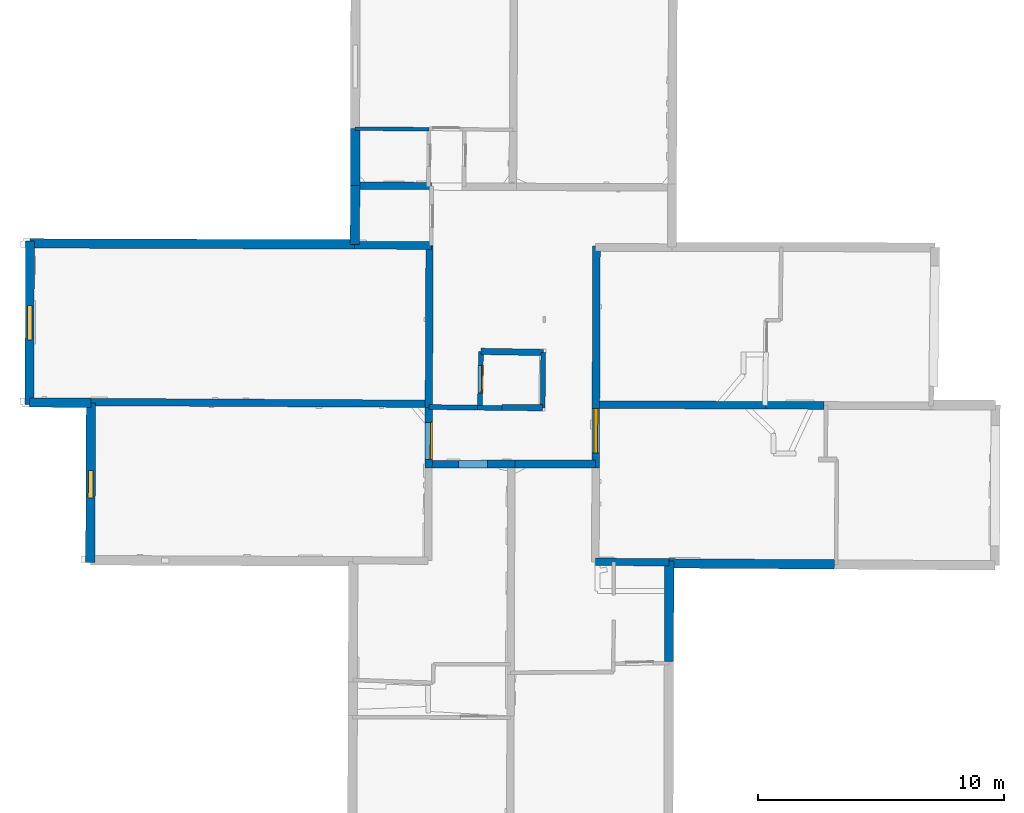
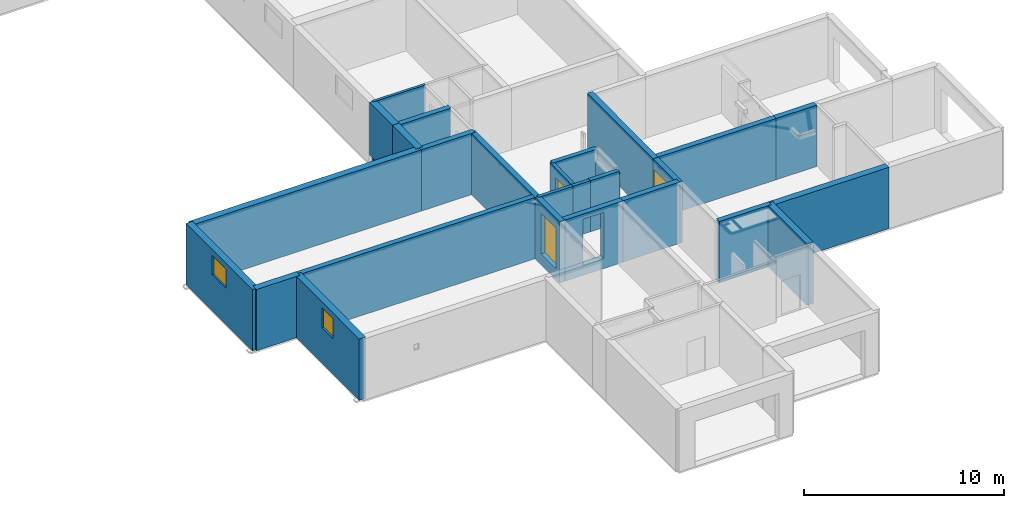
# One storey, part 3 of 12: 27 walls, 3 windows, 2 doors, 6 openings.
"""IFC2X3 building model written with IfcOpenShell, lengths in metres."""

from ifc_helpers import new_model, entity, si_unit, converted_unit, derived_unit, direction, frame, frame_2d, origin, origin_2d_with_axis, place, context, subcontext, project, spatial, polyline, rectangle, outline, extrude, source, transform, mapped, material, layer, layer_set, layer_usage, type_object, type_shapes, element, fill, save


model = new_model("IFC2X3")

# Units and contexts
model_context = context("Model", 3, precision=1e-05, world=origin(), true_north=direction((0.0, 1.0)))
body_context = subcontext(model_context, "Body", "Model", "MODEL_VIEW")
ifc_project = project(units=[si_unit("LENGTHUNIT", "METRE"), si_unit("AREAUNIT", "SQUARE_METRE"), si_unit("VOLUMEUNIT", "CUBIC_METRE"), converted_unit("PLANEANGLEUNIT", "DEGREE", entity("IfcRatioMeasure", 0.0174532925199433), si_unit("PLANEANGLEUNIT", "RADIAN"), dimensions=[0, 0, 0, 0, 0, 0, 0]), si_unit("MASSUNIT", "GRAM", prefix="KILO"), derived_unit("MASSDENSITYUNIT", [(si_unit("MASSUNIT", "GRAM", prefix="KILO"), 1), (si_unit("LENGTHUNIT", "METRE"), -3)]), derived_unit("MOMENTOFINERTIAUNIT", [(si_unit("LENGTHUNIT", "METRE"), 4)]), si_unit("TIMEUNIT", "SECOND"), si_unit("FREQUENCYUNIT", "HERTZ"), si_unit("THERMODYNAMICTEMPERATUREUNIT", "DEGREE_CELSIUS"), derived_unit("THERMALTRANSMITTANCEUNIT", [(si_unit("MASSUNIT", "GRAM", prefix="KILO"), 1), (si_unit("THERMODYNAMICTEMPERATUREUNIT", "KELVIN"), -1), (si_unit("TIMEUNIT", "SECOND"), -3)]), derived_unit("VOLUMETRICFLOWRATEUNIT", [(si_unit("LENGTHUNIT", "METRE"), 3), (si_unit("TIMEUNIT", "SECOND"), -1)]), si_unit("ELECTRICCURRENTUNIT", "AMPERE"), si_unit("ELECTRICVOLTAGEUNIT", "VOLT"), si_unit("POWERUNIT", "WATT"), si_unit("FORCEUNIT", "NEWTON", prefix="KILO"), si_unit("ILLUMINANCEUNIT", "LUX"), si_unit("LUMINOUSFLUXUNIT", "LUMEN"), si_unit("LUMINOUSINTENSITYUNIT", "CANDELA"), derived_unit("USERDEFINED", [(si_unit("MASSUNIT", "GRAM", prefix="KILO"), -1), (si_unit("LENGTHUNIT", "METRE"), -2), (si_unit("TIMEUNIT", "SECOND"), 3), (si_unit("LUMINOUSFLUXUNIT", "LUMEN"), 1)]), derived_unit("LINEARVELOCITYUNIT", [(si_unit("LENGTHUNIT", "METRE"), 1), (si_unit("TIMEUNIT", "SECOND"), -1)]), si_unit("PRESSUREUNIT", "PASCAL"), derived_unit("USERDEFINED", [(si_unit("LENGTHUNIT", "METRE"), -2), (si_unit("MASSUNIT", "GRAM", prefix="KILO"), 1), (si_unit("TIMEUNIT", "SECOND"), -2)]), derived_unit("LINEARFORCEUNIT", [(si_unit("MASSUNIT", "GRAM", prefix="KILO"), 1), (si_unit("LENGTHUNIT", "METRE"), 1), (si_unit("TIMEUNIT", "SECOND"), -2), (si_unit("LENGTHUNIT", "METRE"), -1)]), derived_unit("PLANARFORCEUNIT", [(si_unit("MASSUNIT", "GRAM", prefix="KILO"), 1), (si_unit("LENGTHUNIT", "METRE"), 1), (si_unit("TIMEUNIT", "SECOND"), -2), (si_unit("LENGTHUNIT", "METRE"), -2)])], contexts=[model_context])

# Site, building, storey
placement_1 = place(None, origin())
site = spatial("IfcSite", under=ifc_project, at=placement_1, CompositionType="ELEMENT")
building = spatial("IfcBuilding", under=site, at=placement_1, CompositionType="ELEMENT")
storey_placement = place(placement_1, frame((0.0, 0.0, -1.46125340461731)))
storey = spatial("IfcBuildingStorey", under=building, at=storey_placement, Name="Level 1", CompositionType="ELEMENT", Elevation=-1.46125340461731)

# Walls
ifc_material_1 = material(Name="Default wall")
ifc_layer_1 = layer(ifc_material_1, 0.25)
ifc_layer_set_1 = layer_set([ifc_layer_1], Name="wall_thickness_0.2500")
ifc_layer_usage_1 = layer_usage(ifc_layer_set_1, "AXIS2", "POSITIVE", -0.125)
wall_type_1 = type_object("IfcWallType", Name="wall_thickness_0.2500", PredefinedType="STANDARD", material=ifc_layer_set_1)
placement_2 = place(placement_1, frame((0.0, 0.0, -0.835000038146973)))
wall_1_placement = place(placement_2, frame((5.7840681297067, 19.2895059050723, 0.0), z_axis=(0.0, 0.0, 1.0), x_axis=(0.99997754041984, -0.00670213815785482, 0.0)))
element("IfcWallStandardCase", 1, at=wall_1_placement, inside=storey, type_object=wall_type_1, material=ifc_layer_usage_1, Name="Wall:548", ObjectType="Wall", context=body_context, shape_type="SweptSolid", body=[
    extrude(outline(polyline([(1.65231839470971, -0.125), (1.65231839470971, 0.125), (0.0, 0.125), (0.0, -0.125), (1.65231839470971, -0.125)])), origin(), (0.0, 0.0, 1.0), 3.11573281288147),
])
ifc_layer_2 = layer(ifc_material_1, 0.2)
ifc_layer_set_2 = layer_set([ifc_layer_2], Name="wall_thickness_0.2000")
ifc_layer_usage_2 = layer_usage(ifc_layer_set_2, "AXIS2", "POSITIVE", -0.1)
wall_type_2 = type_object("IfcWallType", Name="wall_thickness_0.2000", PredefinedType="STANDARD", material=ifc_layer_set_2)
placement_3 = place(placement_1, frame((0.0, 0.0, -0.835000038146973)))
wall_2_placement = place(placement_3, frame((7.46238082787132, 21.5249433139177, 0.0), z_axis=(0.0, 0.0, 1.0), x_axis=(-0.0115867312758062, -0.999932871576059, 0.0)))
element("IfcWallStandardCase", 2, at=wall_2_placement, inside=storey, type_object=wall_type_2, material=ifc_layer_usage_2, Name="Wall:515", ObjectType="Wall", context=body_context, shape_type="SweptSolid", body=[
    extrude(outline(polyline([(2.24666418172486, -0.1), (2.24666418172486, 0.1), (0.0, 0.1), (0.0, -0.1), (2.24666418172486, -0.1)])), origin(), (0.0, 0.0, 1.0), 2.39900016784668),
])
placement_4 = place(placement_1, frame((0.0, 0.0, -0.835000038146973)))
wall_3_placement = place(placement_4, frame((2.80981721839884, 19.3082162423228, 0.0), z_axis=(0.0, 0.0, 1.0), x_axis=(0.999909920453089, -0.0134220333592828, 0.0)))
element("IfcWallStandardCase", 3, at=wall_3_placement, inside=storey, type_object=wall_type_2, material=ifc_layer_usage_2, Name="Wall:544", ObjectType="Wall", context=body_context, shape_type="SweptSolid", body=[
    extrude(outline(polyline([(1.97896520963245, -0.1), (1.97896520963245, 0.1), (0.0, 0.1), (0.0, -0.1), (1.97896520963245, -0.1)])), origin(), (0.0, 0.0, 1.0), 3.11573281288147),
])
placement_5 = place(placement_1, frame((0.0, 0.0, -0.835000038146973)))
wall_4_placement = place(placement_5, frame((4.78860416374185, 19.2816545052623, 0.0), z_axis=(0.0, 0.0, 1.0), x_axis=(0.999909915427998, -0.0134224077115114, 0.0)))
element("IfcWallStandardCase", 4, at=wall_4_placement, inside=storey, type_object=wall_type_2, material=ifc_layer_usage_2, Name="Wall:545", ObjectType="Wall", context=body_context, shape_type="SweptSolid", body=[
    extrude(outline(polyline([(0.994428571930101, -0.1), (0.994428571930101, 0.1), (0.0, 0.1), (0.0, -0.1), (0.994428571930101, -0.1)])), origin(), (0.0, 0.0, 1.0), 3.11573281288147),
])

# Wall, opening, door
placement_6 = place(placement_1, frame((0.0, 0.0, -0.835000038146973)))
wall_5_placement = place(placement_6, frame((4.92894918761134, 21.5704102671051, 0.0), z_axis=(0.0, 0.0, 1.0), x_axis=(-0.0176188696174217, -0.999844775669406, 0.0)))
wall_5 = element("IfcWallStandardCase", 5, at=wall_5_placement, inside=storey, type_object=wall_type_2, material=ifc_layer_usage_2, Name="Wall:635", ObjectType="Wall", context=body_context, shape_type="SweptSolid", body=[
    extrude(outline(polyline([(2.29045372445375, -0.1), (2.29045372445375, 0.1), (0.0, 0.1), (0.0, -0.1), (2.29045372445375, -0.1)])), origin(), (0.0, 0.0, 1.0), 3.11573281288147),
])
opening_1_placement = place(wall_5_placement, frame((0.570734855853152, -0.1, 0.0370005369186401)))
opening_1 = element("IfcOpeningElement", 6, at=opening_1_placement, cuts=wall_5, Name="Opening : 1125 x 2495 : 423", ObjectType="Opening", context=body_context, shape_type="SweptSolid", body=[
    extrude(rectangle(XDim=1.125, YDim=2.495, at=frame_2d((1.2475, 0.5625), x_axis=(0.0, 1.0))), frame((0.0, 0.0, 0.0), z_axis=(0.0, 1.0, 0.0), x_axis=(0.0, 0.0, 1.0)), (0.0, 0.0, 1.0), 0.2),
])
ifc_material_2 = material(Name="Door Panel")
door_style_1 = type_object("IfcDoorStyle", Name="Door : 1125 x 2495mm", ConstructionType="NOTDEFINED", OperationType="SINGLE_SWING_RIGHT", ParameterTakesPrecedence=False, Sizeable=False, material=ifc_material_2)
shared_shape_1 = source(origin(), body_context, "Body", "SweptSolid", [
    extrude(rectangle(XDim=0.05, YDim=1.125, at=origin_2d_with_axis()), frame((0.5625, 0.175, 0.0), z_axis=(0.0, 0.0, 1.0), x_axis=(0.0, 1.0, 0.0)), (0.0, 0.0, 1.0), 2.495),
])
type_shapes(door_style_1, [shared_shape_1])
door_1_placement = place(opening_1_placement, origin())
door_1 = element("IfcDoor", 7, at=door_1_placement, inside=storey, type_object=door_style_1, Name="Door : 1125 x 2495mm : 80", ObjectType="Door : 1125 x 2495mm", OverallHeight=2.495, OverallWidth=1.125, context=body_context, shape_type="MappedRepresentation", body=[
    mapped(shared_shape_1, transform((0.0, 0.0, 0.0), scale=1.0)),
])
fill(opening_1, door_1)

# Walls
ifc_layer_3 = layer(ifc_material_1, 0.259999990463257)
ifc_layer_set_3 = layer_set([ifc_layer_3], Name="wall_thickness_0.2600")
ifc_layer_usage_3 = layer_usage(ifc_layer_set_3, "AXIS2", "POSITIVE", -0.129999995231628)
wall_type_3 = type_object("IfcWallType", Name="wall_thickness_0.2600", PredefinedType="STANDARD", material=ifc_layer_set_3)
placement_7 = place(placement_1, frame((0.0, 0.0, -0.835000038146973)))
wall_6_placement = place(placement_7, frame((4.92894941166427, 21.5704125661672, 0.0), z_axis=(0.0, 0.0, 1.0), x_axis=(0.999838965380793, -0.0179455650862475, 0.0)))
element("IfcWallStandardCase", 8, at=wall_6_placement, inside=storey, type_object=wall_type_3, material=ifc_layer_usage_3, Name="Wall:663", ObjectType="Wall", context=body_context, shape_type="SweptSolid", body=[
    extrude(outline(polyline([(2.53384004280236, -0.129999995231628), (2.53384004280236, 0.129999995231628), (0.0, 0.129999995231628), (0.0, -0.129999995231628), (2.53384004280236, -0.129999995231628)])), origin(), (0.0, 0.0, 1.0), 3.11573281288147),
])
ifc_layer_4 = layer(ifc_material_1, 0.379999995231628)
ifc_layer_set_4 = layer_set([ifc_layer_4], Name="wall_thickness_0.3800")
ifc_layer_usage_4 = layer_usage(ifc_layer_set_4, "AXIS2", "POSITIVE", -0.189999997615814)
wall_type_4 = type_object("IfcWallType", Name="wall_thickness_0.3800", PredefinedType="STANDARD", material=ifc_layer_set_4)
wall_7_placement = place(storey_placement, frame((12.5795193033217, 12.954341366673, 0.0), z_axis=(0.0, 0.0, 1.0), x_axis=(0.999980000950745, -0.00632437337200259, 0.0)))
element("IfcWallStandardCase", 9, at=wall_7_placement, inside=storey, type_object=wall_type_4, material=ifc_layer_usage_4, Name="Wall:520", ObjectType="Wall", context=body_context, shape_type="SweptSolid", body=[
    extrude(outline(polyline([(6.70834987412053, -0.189999997615814), (6.70834987412053, 0.189999997615814), (0.0, 0.189999997615814), (0.0, -0.189999997615814), (6.70834987412053, -0.189999997615814)])), origin(), (0.0, 0.0, 1.0), 3.74198617935181),
])

# Wall, opening, window
wall_8_placement = place(storey_placement, frame((-10.9204631501388, 19.4808130808864, 0.0), z_axis=(0.0, 0.0, 1.0), x_axis=(-0.00433199527944714, -0.999990616864428, 0.0)))
wall_8 = element("IfcWallStandardCase", 10, at=wall_8_placement, inside=storey, type_object=wall_type_4, material=ifc_layer_usage_4, Name="Wall:549", ObjectType="Wall", context=body_context, shape_type="SweptSolid", body=[
    extrude(outline(polyline([(6.48772223687164, -0.189999997615814), (6.48772223687164, 0.189999997615814), (0.0, 0.189999997615814), (0.0, -0.189999997615814), (6.48772223687164, -0.189999997615814)])), origin(), (0.0, 0.0, 1.0), 3.74198617935181),
])
opening_2_placement = place(wall_8_placement, frame((2.7444601066649, -0.189999997615814, 2.17525291442871)))
opening_2 = element("IfcOpeningElement", 11, at=opening_2_placement, cuts=wall_8, Name="Opening : 1115 x 1215 : 410", ObjectType="Opening", context=body_context, shape_type="SweptSolid", body=[
    extrude(rectangle(XDim=1.115, YDim=1.215, at=frame_2d((0.6075, 0.5575), x_axis=(0.0, 1.0))), frame((0.0, 0.0, 0.0), z_axis=(0.0, 1.0, 0.0), x_axis=(0.0, 0.0, 1.0)), (0.0, 0.0, 1.0), 0.379999995231628),
])
ifc_material_3 = material(Name="Window Default")
window_style_1 = type_object("IfcWindowStyle", Name="Window : 1115 x 1215mm", ConstructionType="NOTDEFINED", OperationType="NOTDEFINED", ParameterTakesPrecedence=False, Sizeable=False, material=ifc_material_3)
shared_shape_2 = source(origin(), body_context, "Body", "SweptSolid", [
    extrude(rectangle(XDim=0.189999997615814, YDim=1.115, at=origin_2d_with_axis()), frame((0.5575, 0.189999997615814, 0.0), z_axis=(0.0, 0.0, 1.0), x_axis=(0.0, 1.0, 0.0)), (0.0, 0.0, 1.0), 1.215),
])
type_shapes(window_style_1, [shared_shape_2])
window_1_placement = place(opening_2_placement, origin())
window_1 = element("IfcWindow", 12, at=window_1_placement, inside=storey, type_object=window_style_1, Name="Window : 1115 x 1215mm : 228", ObjectType="Window : 1115 x 1215mm", OverallHeight=1.215, OverallWidth=1.115, context=body_context, shape_type="MappedRepresentation", body=[
    mapped(shared_shape_2, transform((0.0, 0.0, 0.0), scale=1.0)),
])
fill(opening_2, window_1)

# Walls
wall_9_placement = place(storey_placement, frame((12.5797761143363, 13.0474977313305, 0.0), z_axis=(0.0, 0.0, 1.0), x_axis=(-0.00275583510850847, -0.999996202679218, 0.0)))
element("IfcWallStandardCase", 13, at=wall_9_placement, inside=storey, type_object=wall_type_4, material=ifc_layer_usage_4, Name="Wall:575", ObjectType="Wall", context=body_context, shape_type="SweptSolid", body=[
    extrude(outline(polyline([(4.07169934521554, -0.189999997615814), (4.07169934521554, 0.189999997615814), (0.0, 0.189999997615814), (0.0, -0.189999997615814), (4.07169934521554, -0.189999997615814)])), origin(), (0.0, 0.0, 1.0), 3.74198617935181),
])
wall_10_placement = place(storey_placement, frame((-13.4005655486695, 25.9596599374144, 0.0), z_axis=(0.0, 0.0, 1.0), x_axis=(0.999994684213053, -0.00326060510279634, 0.0)))
element("IfcWallStandardCase", 14, at=wall_10_placement, inside=storey, type_object=wall_type_4, material=ifc_layer_usage_4, Name="Wall:594", ObjectType="Wall", context=body_context, shape_type="SweptSolid", body=[
    extrude(outline(polyline([(13.2003808775046, -0.189999997615814), (13.2003808775046, 0.189999997615814), (0.0, 0.189999997615814), (0.0, -0.189999997615814), (13.2003808775046, -0.189999997615814)])), origin(), (0.0, 0.0, 1.0), 3.74198617935181),
])
wall_11_placement = place(storey_placement, frame((-13.4193180244992, 19.4954089754104, 0.0), z_axis=(0.0, 0.0, 1.0), x_axis=(0.999982934697878, -0.00584211545754228, 0.0)))
element("IfcWallStandardCase", 15, at=wall_11_placement, inside=storey, type_object=wall_type_4, material=ifc_layer_usage_4, Name="Wall:609", ObjectType="Wall", context=body_context, shape_type="SweptSolid", body=[
    extrude(outline(polyline([(2.49889728158308, -0.189999997615814), (2.49889728158308, 0.189999997615814), (0.0, 0.189999997615814), (0.0, -0.189999997615814), (2.49889728158308, -0.189999997615814)])), origin(), (0.0, 0.0, 1.0), 3.74198617935181),
])
placement_8 = place(placement_1, frame((0.0, 0.0, -0.478000164031982)))
wall_12_placement = place(placement_8, frame((-0.179524466373623, 28.3033261271129, 0.0), z_axis=(0.0, 0.0, 1.0), x_axis=(-0.00868595649302384, -0.999962276368364, 0.0)))
element("IfcWallStandardCase", 16, at=wall_12_placement, inside=storey, type_object=wall_type_4, material=ifc_layer_usage_4, Name="Wall:618", ObjectType="Wall", context=body_context, shape_type="SweptSolid", body=[
    extrude(outline(polyline([(2.38679925199261, -0.189999997615814), (2.38679925199261, 0.189999997615814), (0.0, 0.189999997615814), (0.0, -0.189999997615814), (2.38679925199261, -0.189999997615814)])), origin(), (0.0, 0.0, 1.0), 2.75873293876648),
])
ifc_layer_5 = layer(ifc_material_1, 0.389999985694885)
ifc_layer_set_5 = layer_set([ifc_layer_5], Name="wall_thickness_0.3900")
ifc_layer_usage_5 = layer_usage(ifc_layer_set_5, "AXIS2", "POSITIVE", -0.194999992847443)
wall_type_5 = type_object("IfcWallType", Name="wall_thickness_0.3900", PredefinedType="STANDARD", material=ifc_layer_set_5)
placement_9 = place(placement_1, frame((0.0, 0.0, -0.920999705791473)))
wall_13_placement = place(placement_9, frame((-0.180578001992319, 30.6191854473101, 0.0), z_axis=(0.0, 0.0, 1.0), x_axis=(-0.0012079853838157, -0.99999927038539, 0.0)))
element("IfcWallStandardCase", 17, at=wall_13_placement, inside=storey, type_object=wall_type_5, material=ifc_layer_usage_5, Name="Wall:627", ObjectType="Wall", context=body_context, shape_type="SweptSolid", body=[
    extrude(outline(polyline([(2.31584717917789, -0.194999992847443), (2.31584717917789, 0.194999992847443), (0.0, 0.194999992847443), (0.0, -0.194999992847443), (2.31584717917789, -0.194999992847443)])), origin(), (0.0, 0.0, 1.0), 3.20173248052597),
])

# Wall, opening, window
ifc_layer_6 = layer(ifc_material_1, 0.360000014305115)
ifc_layer_set_6 = layer_set([ifc_layer_6], Name="wall_thickness_0.3600")
ifc_layer_usage_6 = layer_usage(ifc_layer_set_6, "AXIS2", "POSITIVE", -0.180000007152557)
wall_type_6 = type_object("IfcWallType", Name="wall_thickness_0.3600", PredefinedType="STANDARD", material=ifc_layer_set_6)
wall_14_placement = place(storey_placement, frame((-13.4002913410613, 26.053958472118, 0.0), z_axis=(0.0, 0.0, 1.0), x_axis=(-0.00290102915586475, -0.999995792006065, 0.0)))
wall_14 = element("IfcWallStandardCase", 18, at=wall_14_placement, inside=storey, type_object=wall_type_6, material=ifc_layer_usage_6, Name="Wall:582", ObjectType="Wall", context=body_context, shape_type="SweptSolid", body=[
    extrude(outline(polyline([(6.65034040829816, -0.180000007152557), (6.65034040829816, 0.180000007152557), (0.0, 0.180000007152557), (0.0, -0.180000007152557), (6.65034040829816, -0.180000007152557)])), origin(), (0.0, 0.0, 1.0), 3.74198617935181),
])
opening_3_placement = place(wall_14_placement, frame((2.61791377790112, -0.180000007152557, 2.20525360107422)))
opening_3 = element("IfcOpeningElement", 19, at=opening_3_placement, cuts=wall_14, Name="Opening : 1395 x 1180 : 416", ObjectType="Opening", context=body_context, shape_type="SweptSolid", body=[
    extrude(rectangle(XDim=1.395, YDim=1.18, at=frame_2d((0.59, 0.6975), x_axis=(0.0, 1.0))), frame((0.0, 0.0, 0.0), z_axis=(0.0, 1.0, 0.0), x_axis=(0.0, 0.0, 1.0)), (0.0, 0.0, 1.0), 0.360000014305115),
])
window_style_2 = type_object("IfcWindowStyle", Name="Window : 1395 x 1180mm", ConstructionType="NOTDEFINED", OperationType="NOTDEFINED", ParameterTakesPrecedence=False, Sizeable=False, material=ifc_material_3)
shared_shape_3 = source(origin(), body_context, "Body", "SweptSolid", [
    extrude(rectangle(XDim=0.180000007152557, YDim=1.395, at=origin_2d_with_axis()), frame((0.6975, 0.180000007152557, 0.0), z_axis=(0.0, 0.0, 1.0), x_axis=(0.0, 1.0, 0.0)), (0.0, 0.0, 1.0), 1.18),
])
type_shapes(window_style_2, [shared_shape_3])
window_2_placement = place(opening_3_placement, origin())
window_2 = element("IfcWindow", 20, at=window_2_placement, inside=storey, type_object=window_style_2, Name="Window : 1395 x 1180mm : 231", ObjectType="Window : 1395 x 1180mm", OverallHeight=1.18, OverallWidth=1.395, context=body_context, shape_type="MappedRepresentation", body=[
    mapped(shared_shape_3, transform((0.0, 0.0, 0.0), scale=1.0)),
])
fill(opening_3, window_2)

# Walls
ifc_layer_7 = layer(ifc_material_1, 0.150000005960464)
ifc_layer_set_7 = layer_set([ifc_layer_7], Name="wall_thickness_0.1500")
ifc_layer_usage_7 = layer_usage(ifc_layer_set_7, "AXIS2", "POSITIVE", -0.0750000029802322)
wall_type_7 = type_object("IfcWallType", Name="wall_thickness_0.1500", PredefinedType="STANDARD", material=ifc_layer_set_7)
wall_15_placement = place(storey_placement, frame((-0.193405611720425, 30.6192668444416, 0.0), z_axis=(0.0, 0.0, 1.0), x_axis=(0.99998024311138, -0.00628596745975804, 0.0)))
element("IfcWallStandardCase", 21, at=wall_15_placement, inside=storey, type_object=wall_type_7, material=ifc_layer_usage_7, Name="Wall:533", ObjectType="Wall", context=body_context, shape_type="SweptSolid", body=[
    extrude(outline(polyline([(3.00577368203047, -0.0750000029802322), (3.00577368203047, 0.0750000029802322), (0.0, 0.0750000029802322), (0.0, -0.0750000029802322), (3.00577368203047, -0.0750000029802322)])), origin(), (0.0, 0.0, 1.0), 3.74198617935181),
])
ifc_layer_8 = layer(ifc_material_1, 0.300000011920929)
ifc_layer_set_8 = layer_set([ifc_layer_8], Name="wall_thickness_0.3000")
ifc_layer_usage_8 = layer_usage(ifc_layer_set_8, "AXIS2", "POSITIVE", -0.150000005960464)
wall_type_8 = type_object("IfcWallType", Name="wall_thickness_0.3000", PredefinedType="STANDARD", material=ifc_layer_set_8)
wall_16_placement = place(storey_placement, frame((9.57800638603752, 13.0190444386877, 0.0), z_axis=(0.0, 0.0, 1.0), x_axis=(0.999975427651589, -0.0070102848031567, 0.0)))
element("IfcWallStandardCase", 22, at=wall_16_placement, inside=storey, type_object=wall_type_8, material=ifc_layer_usage_8, Name="Wall:519", ObjectType="Wall", context=body_context, shape_type="SweptSolid", body=[
    extrude(outline(polyline([(3.00170740310414, -0.150000005960464), (3.00170740310414, 0.150000005960464), (0.0, 0.150000005960464), (0.0, -0.150000005960464), (3.00170740310414, -0.150000005960464)])), origin(), (0.0, 0.0, 1.0), 3.74198617935181),
])
wall_17_placement = place(storey_placement, frame((-10.9203336489833, 19.510809298128, 0.0), z_axis=(0.0, 0.0, 1.0), x_axis=(0.999987057668284, -0.00508768080052602, 0.0)))
element("IfcWallStandardCase", 23, at=wall_17_placement, inside=storey, type_object=wall_type_8, material=ifc_layer_usage_8, Name="Wall:626", ObjectType="Wall", context=body_context, shape_type="SweptSolid", body=[
    extrude(outline(polyline([(13.730922548869, -0.150000005960464), (13.730922548869, 0.150000005960464), (0.0, 0.150000005960464), (0.0, -0.150000005960464), (13.730922548869, -0.150000005960464)])), origin(), (0.0, 0.0, 1.0), 3.74198617935181),
])
wall_18_placement = place(storey_placement, frame((2.83912881646446, 25.8717056228099, 0.0), z_axis=(0.0, 0.0, 1.0), x_axis=(-0.00446577059296035, -0.999990028396789, 0.0)))
element("IfcWallStandardCase", 24, at=wall_18_placement, inside=storey, type_object=wall_type_8, material=ifc_layer_usage_8, Name="Wall:658", ObjectType="Wall", context=body_context, shape_type="SweptSolid", body=[
    extrude(outline(polyline([(6.58081894773137, -0.150000005960464), (6.58081894773137, 0.150000005960464), (0.0, 0.150000005960464), (0.0, -0.150000005960464), (6.58081894773137, -0.150000005960464)])), origin(), (0.0, 0.0, 1.0), 3.74198617935181),
])

# Wall, opening, door
wall_19_placement = place(storey_placement, frame((2.80974038873009, 19.2909522963939, 0.0), z_axis=(0.0, 0.0, 1.0), x_axis=(-0.00446572428047617, -0.999990028603611, 0.0)))
wall_19 = element("IfcWallStandardCase", 25, at=wall_19_placement, inside=storey, type_object=wall_type_8, material=ifc_layer_usage_8, Name="Wall:659", ObjectType="Wall", context=body_context, shape_type="SweptSolid", body=[
    extrude(outline(polyline([(2.4573151522775, -0.150000005960464), (2.4573151522775, 0.150000005960464), (0.0, 0.150000005960464), (0.0, -0.150000005960464), (2.4573151522775, -0.150000005960464)])), origin(), (0.0, 0.0, 1.0), 3.74198617935181),
])
opening_4_placement = place(wall_19_placement, frame((0.601919446987097, -0.150000005960464, 0.665253758430481)))
opening_4 = element("IfcOpeningElement", 26, at=opening_4_placement, cuts=wall_19, Name="Opening : 1505 x 2460 : 427", ObjectType="Opening", context=body_context, shape_type="SweptSolid", body=[
    extrude(rectangle(XDim=1.505, YDim=2.46, at=frame_2d((1.23, 0.7525), x_axis=(0.0, 1.0))), frame((0.0, 0.0, 0.0), z_axis=(0.0, 1.0, 0.0), x_axis=(0.0, 0.0, 1.0)), (0.0, 0.0, 1.0), 0.300000011920929),
])
door_style_2 = type_object("IfcDoorStyle", Name="Door : 1505 x 2460mm", ConstructionType="NOTDEFINED", OperationType="SINGLE_SWING_RIGHT", ParameterTakesPrecedence=False, Sizeable=False, material=ifc_material_2)
shared_shape_4 = source(origin(), body_context, "Body", "SweptSolid", [
    extrude(rectangle(XDim=0.0750000029802322, YDim=1.505, at=origin_2d_with_axis()), frame((0.7525, 0.262500010430813, 0.0), z_axis=(0.0, 0.0, 1.0), x_axis=(0.0, 1.0, 0.0)), (0.0, 0.0, 1.0), 2.46),
])
type_shapes(door_style_2, [shared_shape_4])
door_2_placement = place(opening_4_placement, origin())
door_2 = element("IfcDoor", 27, at=door_2_placement, inside=storey, type_object=door_style_2, Name="Door : 1505 x 2460mm : 82", ObjectType="Door : 1505 x 2460mm", OverallHeight=2.46, OverallWidth=1.505, context=body_context, shape_type="MappedRepresentation", body=[
    mapped(shared_shape_4, transform((0.0, 0.0, 0.0), scale=1.0)),
])
fill(opening_4, door_2)

# Walls
placement_10 = place(placement_1, frame((0.0, 0.0, -0.835000038146973)))
wall_20_placement = place(placement_10, frame((-0.279491169492628, 28.3037155066954, 0.0), z_axis=(0.0, 0.0, 1.0), x_axis=(0.999992385870436, -0.00390233278354446, 0.0)))
element("IfcWallStandardCase", 28, at=wall_20_placement, inside=storey, type_object=wall_type_8, material=ifc_layer_usage_8, Name="Wall:664", ObjectType="Wall", context=body_context, shape_type="SweptSolid", body=[
    extrude(outline(polyline([(3.19754245677782, -0.150000005960464), (3.19754245677782, 0.150000005960464), (0.0, 0.150000005960464), (0.0, -0.150000005960464), (3.19754245677782, -0.150000005960464)])), origin(), (0.0, 0.0, 1.0), 3.11573281288147),
])
ifc_layer_9 = layer(ifc_material_1, 0.310000002384186)
ifc_layer_set_9 = layer_set([ifc_layer_9], Name="wall_thickness_0.3100")
ifc_layer_usage_9 = layer_usage(ifc_layer_set_9, "AXIS2", "POSITIVE", -0.155000001192093)
wall_type_9 = type_object("IfcWallType", Name="wall_thickness_0.3100", PredefinedType="STANDARD", material=ifc_layer_set_9)
wall_21_placement = place(storey_placement, frame((9.60065301729338, 19.4084567526987, 0.0), z_axis=(0.0, 0.0, 1.0), x_axis=(0.999991797293305, -0.0040503513557661, 0.0)))
element("IfcWallStandardCase", 29, at=wall_21_placement, inside=storey, type_object=wall_type_9, material=ifc_layer_usage_9, Name="Wall:591", ObjectType="Wall", context=body_context, shape_type="SweptSolid", body=[
    extrude(outline(polyline([(6.92236856499589, -0.155000001192093), (6.92236856499589, 0.155000001192093), (0.0, 0.155000001192093), (0.0, -0.155000001192093), (6.92236856499589, -0.155000001192093)])), origin(), (0.0, 0.0, 1.0), 3.74198617935181),
])
wall_22_placement = place(storey_placement, frame((16.5229648001303, 19.3804187277964, 0.0), z_axis=(0.0, 0.0, 1.0), x_axis=(0.999991794595832, -0.00405101728066628, 0.0)))
element("IfcWallStandardCase", 30, at=wall_22_placement, inside=storey, type_object=wall_type_9, material=ifc_layer_usage_9, Name="Wall:592", ObjectType="Wall", context=body_context, shape_type="SweptSolid", body=[
    extrude(outline(polyline([(2.35651423971622, -0.155000001192093), (2.35651423971622, 0.155000001192093), (0.0, 0.155000001192093), (0.0, -0.155000001192093), (2.35651423971622, -0.155000001192093)])), origin(), (0.0, 0.0, 1.0), 3.74198617935181),
])
wall_23_placement = place(storey_placement, frame((-0.200560617230783, 25.8816188976841, 0.0), z_axis=(0.0, 0.0, 1.0), x_axis=(0.999994683161737, -0.00326092751472509, 0.0)))
element("IfcWallStandardCase", 31, at=wall_23_placement, inside=storey, type_object=wall_type_9, material=ifc_layer_usage_9, Name="Wall:595", ObjectType="Wall", context=body_context, shape_type="SweptSolid", body=[
    extrude(outline(polyline([(3.11172041719484, -0.155000001192093), (3.11172041719484, 0.155000001192093), (0.0, 0.155000001192093), (0.0, -0.155000001192093), (3.11172041719484, -0.155000001192093)])), origin(), (0.0, 0.0, 1.0), 3.74198617935181),
])
wall_24_placement = place(storey_placement, frame((9.62352918601444, 25.8619481036479, 0.0), z_axis=(0.0, 0.0, 1.0), x_axis=(-0.00354467690257257, -0.999993717613094, 0.0)))
element("IfcWallStandardCase", 32, at=wall_24_placement, inside=storey, type_object=wall_type_9, material=ifc_layer_usage_9, Name="Wall:619", ObjectType="Wall", context=body_context, shape_type="SweptSolid", body=[
    extrude(outline(polyline([(6.60852960022557, -0.155000001192093), (6.60852960022557, 0.155000001192093), (0.0, 0.155000001192093), (0.0, -0.155000001192093), (6.60852960022557, -0.155000001192093)])), origin(), (0.0, 0.0, 1.0), 3.74198617935181),
])

# Wall, opening, window
wall_25_placement = place(storey_placement, frame((9.60010408378055, 19.2534600207622, 0.0), z_axis=(0.0, 0.0, 1.0), x_axis=(-0.00354451287335338, -0.999993718194515, 0.0)))
wall_25 = element("IfcWallStandardCase", 33, at=wall_25_placement, inside=storey, type_object=wall_type_9, material=ifc_layer_usage_9, Name="Wall:620", ObjectType="Wall", context=body_context, shape_type="SweptSolid", body=[
    extrude(outline(polyline([(2.41289891590657, -0.155000001192093), (2.41289891590657, 0.155000001192093), (0.0, 0.155000001192093), (0.0, -0.155000001192093), (2.41289891590657, -0.155000001192093)])), origin(), (0.0, 0.0, 1.0), 3.74198617935181),
])
opening_5_placement = place(wall_25_placement, frame((0.0104332671829531, -0.155000001192093, 0.40925395488739)))
opening_5 = element("IfcOpeningElement", 34, at=opening_5_placement, cuts=wall_25, Name="Opening : 1795 x 2720 : 422", ObjectType="Opening", context=body_context, shape_type="SweptSolid", body=[
    extrude(rectangle(XDim=1.795, YDim=2.72, at=frame_2d((1.36, 0.8975), x_axis=(0.0, 1.0))), frame((0.0, 0.0, 0.0), z_axis=(0.0, 1.0, 0.0), x_axis=(0.0, 0.0, 1.0)), (0.0, 0.0, 1.0), 0.310000002384186),
])
window_style_3 = type_object("IfcWindowStyle", Name="Window : 1795 x 2720mm", ConstructionType="NOTDEFINED", OperationType="NOTDEFINED", ParameterTakesPrecedence=False, Sizeable=False, material=ifc_material_3)
shared_shape_5 = source(origin(), body_context, "Body", "SweptSolid", [
    extrude(rectangle(XDim=0.155000001192093, YDim=1.795, at=origin_2d_with_axis()), frame((0.8975, 0.155000001192093, 0.0), z_axis=(0.0, 0.0, 1.0), x_axis=(0.0, 1.0, 0.0)), (0.0, 0.0, 1.0), 2.72),
])
type_shapes(window_style_3, [shared_shape_5])
window_3_placement = place(opening_5_placement, origin())
window_3 = element("IfcWindow", 35, at=window_3_placement, inside=storey, type_object=window_style_3, Name="Window : 1795 x 2720mm : 233", ObjectType="Window : 1795 x 2720mm", OverallHeight=2.72, OverallWidth=1.795, context=body_context, shape_type="MappedRepresentation", body=[
    mapped(shared_shape_5, transform((0.0, 0.0, 0.0), scale=1.0)),
])
fill(opening_5, window_3)

# Wall, opening
wall_26_placement = place(storey_placement, frame((2.79945804722616, 16.9886581392376, 0.0), z_axis=(0.0, 0.0, 1.0), x_axis=(0.999999481442658, 0.00101838814597018, 0.0)))
wall_26 = element("IfcWallStandardCase", 36, at=wall_26_placement, inside=storey, type_object=wall_type_9, material=ifc_layer_usage_9, Name="Wall:669", ObjectType="Wall", context=body_context, shape_type="SweptSolid", body=[
    extrude(outline(polyline([(3.51357785272279, -0.155000001192093), (3.51357785272279, 0.155000001192093), (0.0, 0.155000001192093), (0.0, -0.155000001192093), (3.51357785272279, -0.155000001192093)])), origin(), (0.0, 0.0, 1.0), 3.74198617935181),
])
opening_6_placement = place(wall_26_placement, frame((1.21203481629649, -0.155000001192093, 0.619253277778625)))
element("IfcOpeningElement", 37, at=opening_6_placement, cuts=wall_26, Name="Opening : 1190 x 2810 : 428", ObjectType="Opening", context=body_context, shape_type="SweptSolid", body=[
    extrude(rectangle(XDim=1.19, YDim=2.81, at=frame_2d((1.405, 0.595), x_axis=(0.0, 1.0))), frame((0.0, 0.0, 0.0), z_axis=(0.0, 1.0, 0.0), x_axis=(0.0, 0.0, 1.0)), (0.0, 0.0, 1.0), 0.310000002384186),
])

# Wall
wall_27_placement = place(storey_placement, frame((6.31303407795737, 16.9922363252727, 0.0), z_axis=(0.0, 0.0, 1.0), x_axis=(0.9999994819103, 0.00101792884431891, 0.0)))
element("IfcWallStandardCase", 38, at=wall_27_placement, inside=storey, type_object=wall_type_9, material=ifc_layer_usage_9, Name="Wall:670", ObjectType="Wall", context=body_context, shape_type="SweptSolid", body=[
    extrude(outline(polyline([(3.2790701688537, -0.155000001192093), (3.2790701688537, 0.155000001192093), (0.0, 0.155000001192093), (0.0, -0.155000001192093), (3.2790701688537, -0.155000001192093)])), origin(), (0.0, 0.0, 1.0), 3.74198617935181),
])

save(model, "model.ifc")
